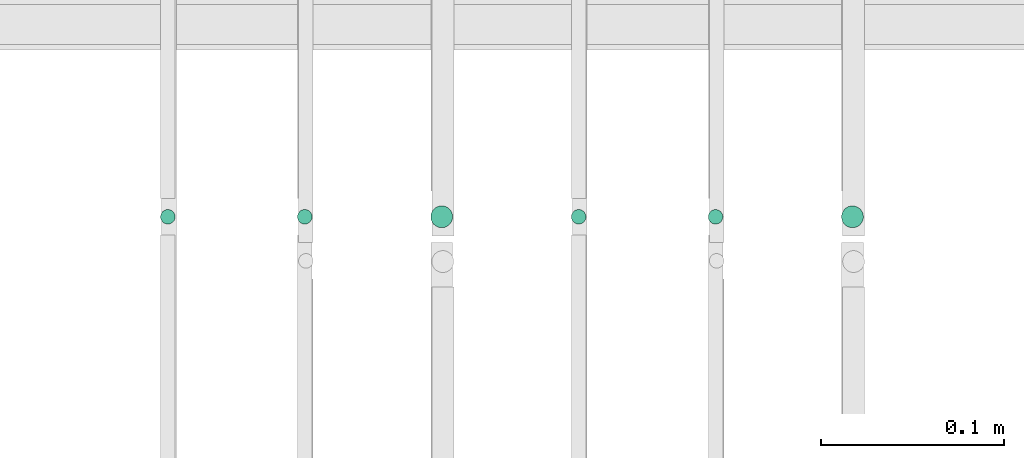
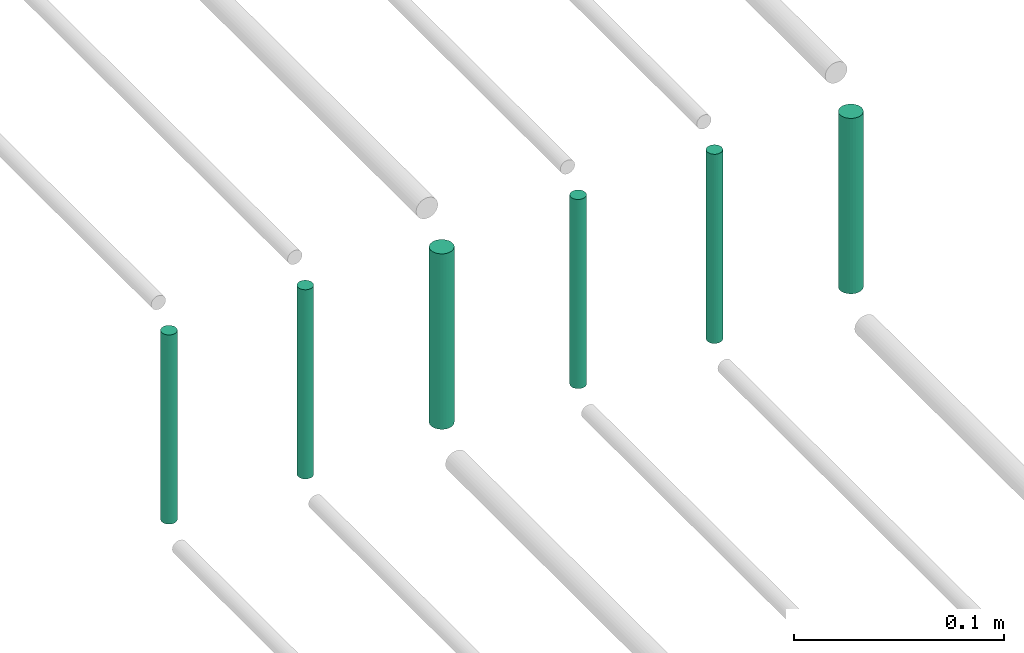
# One storey, part 199 of 331: 6 flow segments.
"""IFC2X3 building model written with IfcOpenShell, lengths in millimetres."""

from ifc_helpers import new_model, entity, si_unit, converted_unit, derived_unit, direction, frame, frame_2d, origin, origin_2d_with_axis, place, context, subcontext, project, spatial, circle, extrude, type_object, element, save


model = new_model("IFC2X3")

# Units and contexts
model_context = context("Model", 3, precision=0.01, world=origin(), true_north=direction((6.12303176911189e-17, 1.0)))
body_context = subcontext(model_context, "Body", "Model", "MODEL_VIEW")
ifc_project = project(units=[si_unit("LENGTHUNIT", "METRE", prefix="MILLI"), si_unit("AREAUNIT", "SQUARE_METRE"), si_unit("VOLUMEUNIT", "CUBIC_METRE"), converted_unit("PLANEANGLEUNIT", "DEGREE", entity("IfcRatioMeasure", 0.0174532925199433), si_unit("PLANEANGLEUNIT", "RADIAN"), dimensions=[0, 0, 0, 0, 0, 0, 0]), si_unit("MASSUNIT", "GRAM", prefix="KILO"), derived_unit("MASSDENSITYUNIT", [(si_unit("MASSUNIT", "GRAM", prefix="KILO"), 1), (si_unit("LENGTHUNIT", "METRE"), -3)]), derived_unit("MOMENTOFINERTIAUNIT", [(si_unit("LENGTHUNIT", "METRE"), 4)]), si_unit("TIMEUNIT", "SECOND"), si_unit("FREQUENCYUNIT", "HERTZ"), si_unit("THERMODYNAMICTEMPERATUREUNIT", "DEGREE_CELSIUS"), derived_unit("THERMALTRANSMITTANCEUNIT", [(si_unit("MASSUNIT", "GRAM", prefix="KILO"), 1), (si_unit("THERMODYNAMICTEMPERATUREUNIT", "KELVIN"), -1), (si_unit("TIMEUNIT", "SECOND"), -3)]), derived_unit("VOLUMETRICFLOWRATEUNIT", [(si_unit("LENGTHUNIT", "METRE"), 3), (si_unit("TIMEUNIT", "SECOND"), -1)]), derived_unit("MASSFLOWRATEUNIT", [(si_unit("MASSUNIT", "GRAM", prefix="KILO"), 1), (si_unit("TIMEUNIT", "SECOND"), -1)]), derived_unit("ROTATIONALFREQUENCYUNIT", [(si_unit("TIMEUNIT", "SECOND"), -1)]), si_unit("ELECTRICCURRENTUNIT", "AMPERE"), si_unit("ELECTRICVOLTAGEUNIT", "VOLT"), si_unit("POWERUNIT", "WATT"), si_unit("FORCEUNIT", "NEWTON", prefix="KILO"), si_unit("ILLUMINANCEUNIT", "LUX"), si_unit("LUMINOUSFLUXUNIT", "LUMEN"), si_unit("LUMINOUSINTENSITYUNIT", "CANDELA"), derived_unit("USERDEFINED", [(si_unit("MASSUNIT", "GRAM", prefix="KILO"), -1), (si_unit("LENGTHUNIT", "METRE"), -2), (si_unit("TIMEUNIT", "SECOND"), 3), (si_unit("LUMINOUSFLUXUNIT", "LUMEN"), 1)]), derived_unit("LINEARVELOCITYUNIT", [(si_unit("LENGTHUNIT", "METRE"), 1), (si_unit("TIMEUNIT", "SECOND"), -1)]), si_unit("PRESSUREUNIT", "PASCAL"), derived_unit("USERDEFINED", [(si_unit("LENGTHUNIT", "METRE"), -2), (si_unit("MASSUNIT", "GRAM", prefix="KILO"), 1), (si_unit("TIMEUNIT", "SECOND"), -2)]), derived_unit("LINEARFORCEUNIT", [(si_unit("MASSUNIT", "GRAM", prefix="KILO"), 1), (si_unit("LENGTHUNIT", "METRE"), 1), (si_unit("TIMEUNIT", "SECOND"), -2), (si_unit("LENGTHUNIT", "METRE"), -1)]), derived_unit("PLANARFORCEUNIT", [(si_unit("MASSUNIT", "GRAM", prefix="KILO"), 1), (si_unit("LENGTHUNIT", "METRE"), 1), (si_unit("TIMEUNIT", "SECOND"), -2), (si_unit("LENGTHUNIT", "METRE"), -2)])], contexts=[model_context])

# Site, building, storey
site_placement = place(None, frame((0.0, -0.00077364408347762, 0.0)))
site = spatial("IfcSite", under=ifc_project, at=site_placement, CompositionType="ELEMENT")
building_placement = place(site_placement, origin())
building = spatial("IfcBuilding", under=site, at=building_placement, CompositionType="ELEMENT")
storey_placement = place(building_placement, origin())
storey = spatial("IfcBuildingStorey", under=building, at=storey_placement, CompositionType="ELEMENT", Elevation=0.0)

# Flow segments
pipe_segment_type = type_object("IfcPipeSegmentType", PredefinedType="NOTDEFINED")
flow_segment_1_placement = place(storey_placement, frame((52664.4468045266, 8084.55353441893, 18460.0)))
element("IfcFlowSegment", 1, at=flow_segment_1_placement, inside=storey, type_object=pipe_segment_type, context=body_context, shape_type="SweptSolid", body=[
    extrude(circle(Radius=4.0, at=frame_2d((0.0, 1.08286712929839e-12), x_axis=(1.0, 0.0))), frame((5.59527223591499, 5.59527223591716, 0.0), z_axis=(0.0, 0.0, 1.0), x_axis=(-1.0, 0.0, 0.0)), (0.0, 0.0, 1.0), 110.000000000014),
])
flow_segment_2_placement = place(storey_placement, frame((52739.4468045266, 8084.55353441892, 18460.0)))
element("IfcFlowSegment", 2, at=flow_segment_2_placement, inside=storey, type_object=pipe_segment_type, context=body_context, shape_type="SweptSolid", body=[
    extrude(circle(Radius=4.0, at=frame_2d((0.0, -1.08286712929839e-12), x_axis=(1.0, 0.0))), frame((5.59527223591499, 5.59527223591716, 0.0)), (0.0, 0.0, 1.0), 110.00000000001),
])
flow_segment_3_placement = place(storey_placement, frame((52812.4468045266, 8082.55353441901, 18464.0)))
element("IfcFlowSegment", 3, at=flow_segment_3_placement, inside=storey, type_object=pipe_segment_type, context=body_context, shape_type="SweptSolid", body=[
    extrude(circle(Radius=6.0, at=origin_2d_with_axis()), frame((7.59527223591454, 7.59527223591562, 0.0), z_axis=(0.0, 0.0, 1.0), x_axis=(-1.0, 0.0, 0.0)), (0.0, 0.0, 1.0), 102.000000000014),
])
flow_segment_4_placement = place(storey_placement, frame((52889.4468045266, 8084.55353441901, 18460.0)))
element("IfcFlowSegment", 4, at=flow_segment_4_placement, inside=storey, type_object=pipe_segment_type, context=body_context, shape_type="SweptSolid", body=[
    extrude(circle(Radius=4.0, at=origin_2d_with_axis()), frame((5.59527223591499, 5.59527223591607, 0.0), z_axis=(0.0, 0.0, 1.0), x_axis=(-1.0, 0.0, 0.0)), (0.0, 0.0, 1.0), 110.000000000053),
])
flow_segment_5_placement = place(storey_placement, frame((52964.4468045266, 8084.55353441901, 18460.0)))
element("IfcFlowSegment", 5, at=flow_segment_5_placement, inside=storey, type_object=pipe_segment_type, context=body_context, shape_type="SweptSolid", body=[
    extrude(circle(Radius=4.0, at=origin_2d_with_axis()), frame((5.59527223591499, 5.59527223591607, 0.0), z_axis=(0.0, 0.0, 1.0), x_axis=(-1.0, 0.0, 0.0)), (0.0, 0.0, 1.0), 110.000000000036),
])
flow_segment_6_placement = place(storey_placement, frame((53037.4468045266, 8082.55353441901, 18464.0)))
element("IfcFlowSegment", 6, at=flow_segment_6_placement, inside=storey, type_object=pipe_segment_type, context=body_context, shape_type="SweptSolid", body=[
    extrude(circle(Radius=6.0, at=origin_2d_with_axis()), frame((7.59527223591454, 7.59527223591562, 0.0), z_axis=(0.0, 0.0, 1.0), x_axis=(-1.0, 0.0, 0.0)), (0.0, 0.0, 1.0), 102.000000000055),
])

save(model, "model.ifc")
